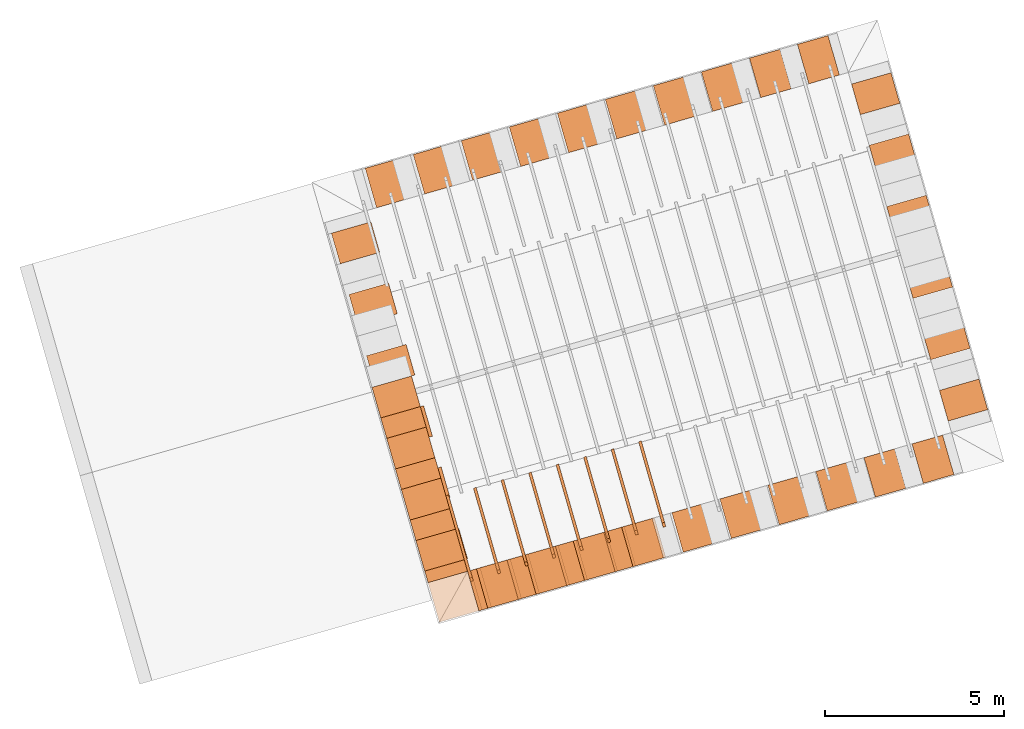
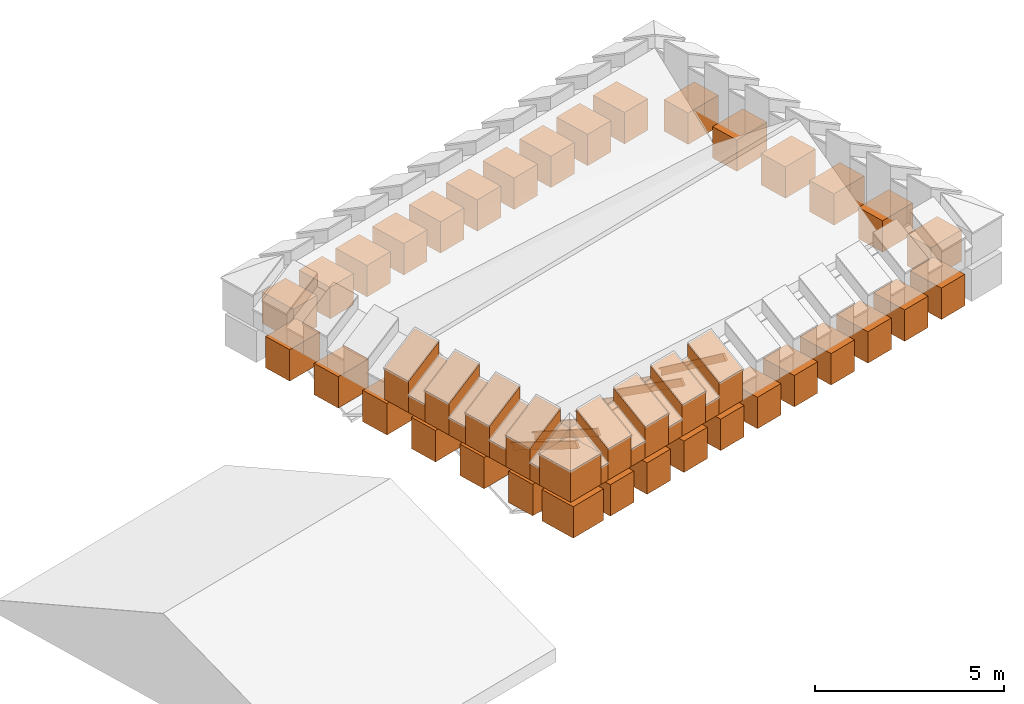
# One storey, part 5 of 10: 58 proxies.
"""IFC4 building model written with IfcOpenShell, lengths in metres."""

from ifc_helpers import new_model, entity, si_unit, converted_unit, derived_unit, direction, frame, origin_with_axes, place, context, subcontext, project, spatial, polygons, source, transform, mapped, material, type_object, element, save


model = new_model("IFC4")

# Units and contexts
model_context = context("Model", 3, precision=1e-05, world=origin_with_axes(), true_north=direction((0.0, 1.0)))
body_context = subcontext(model_context, "Body", "Model", "MODEL_VIEW")
ifc_project = project(units=[si_unit("LENGTHUNIT", "METRE"), si_unit("AREAUNIT", "SQUARE_METRE"), si_unit("VOLUMEUNIT", "CUBIC_METRE"), converted_unit("PLANEANGLEUNIT", "DEGREE", entity("IfcPlaneAngleMeasure", 0.0174532925199433), si_unit("PLANEANGLEUNIT", "RADIAN"), dimensions=[0, 0, 0, 0, 0, 0, 0]), converted_unit("TIMEUNIT", "Year", entity("IfcTimeMeasure", 31557600.0), si_unit("TIMEUNIT", "SECOND"), dimensions=[0, 0, 1, 0, 0, 0, 0]), si_unit("MASSUNIT", "GRAM", prefix="KILO"), si_unit("THERMODYNAMICTEMPERATUREUNIT", "DEGREE_CELSIUS"), si_unit("LUMINOUSINTENSITYUNIT", "LUMEN"), si_unit("ENERGYUNIT", "JOULE", prefix="MEGA"), derived_unit("THERMALCONDUCTANCEUNIT", [(si_unit("POWERUNIT", "WATT"), 1), (si_unit("LENGTHUNIT", "METRE"), -1), (si_unit("THERMODYNAMICTEMPERATUREUNIT", "KELVIN"), -1)]), derived_unit("SPECIFICHEATCAPACITYUNIT", [(si_unit("ENERGYUNIT", "JOULE"), 1), (si_unit("MASSUNIT", "GRAM", prefix="KILO"), -1), (si_unit("THERMODYNAMICTEMPERATUREUNIT", "KELVIN"), -1)]), derived_unit("MASSDENSITYUNIT", [(si_unit("MASSUNIT", "GRAM", prefix="KILO"), 1), (si_unit("VOLUMEUNIT", "CUBIC_METRE"), -1)])], contexts=[model_context])

# Site, building, storey
site_placement = place(None, frame((0.0, 0.0, 0.0), z_axis=(0.0, 0.0, 1.0), x_axis=(0.9612616959383189, 0.2756373558169991, 0.0)))
site = spatial("IfcSite", under=ifc_project, at=site_placement, CompositionType="ELEMENT")
building_placement = place(site_placement, origin_with_axes())
building = spatial("IfcBuilding", under=site, at=building_placement, CompositionType="ELEMENT")
storey_placement = place(building_placement, frame((0.0, 0.0, 11.0), z_axis=(0.0, 0.0, 1.0), x_axis=(1.0, 0.0, 0.0)))
storey = spatial("IfcBuildingStorey", under=building, at=storey_placement, Name="Dach", CompositionType="ELEMENT", Elevation=11.0)

# Proxies
ifc_material_1 = material()
building_element_proxy_type_1 = type_object("IfcBuildingElementProxyType", PredefinedType="NOTDEFINED")
shared_shape = source(origin_with_axes(), body_context, "Body", "Tessellation", [
    polygons([(29.30246798608733, 19.30664615992103, 30.0), (29.30246799091987, 18.15664615992103, 30.0), (29.30246799091987, 18.15664615992103, 31.0117), (29.30246798608733, 19.30664615992103, 31.0117), (30.19247054778258, 19.30664616366101, 30.0), (30.19247055261512, 18.15664616366101, 30.0), (30.19247055261512, 18.15664616366101, 31.0117), (30.19247054778258, 19.30664616366101, 31.0117)], [[[1, 2, 3, 4]], [[2, 1, 5, 6]], [[2, 6, 7, 3]], [[4, 3, 7, 8]], [[1, 4, 8, 5]], [[7, 6, 5, 8]]], closed=True),
])
for number, where, z_axis, x_axis in (
    (1, (-2.796313213619531, 1.1039726491191e-05, -31.0), (0.0, 0.0, 1.0), (1.0, 0.0, 0.0)),
    (2, (12.29478534732825, 43.55533738798009, -30.99999999999999), (0.0, 0.0, 1.0), (-4.202178160994663e-09, -1.0, 0.0)),
    (3, (-2.846450438079298, 41.77164896513582, -31.00000000000001), (0.0, 0.0, 1.0), (-4.202178160994663e-09, -1.0, 0.0)),
    (4, (-2.84645043807933, 38.2042721194473, -31.00000000000002), (0.0, 0.0, 1.0), (-4.202178160994663e-09, -1.0, 0.0)),
    (5, (-2.84645043807928, 43.55533738798009, -31.00000000000001), (0.0, 0.0, 1.0), (-4.202178160994663e-09, -1.0, 0.0)),
    (6, (12.29478534732826, 45.33902581082435, -30.99999999999999), (0.0, 0.0, 1.0), (-4.202178160994663e-09, -1.0, 0.0)),
    (7, (-1.398176188643454, 5.520714232432056e-06, -31.0), (0.0, 0.0, 1.0), (1.0, 0.0, 0.0)),
    (8, (12.2947853473282, 38.2042721194473, -31.00000000000001), (0.0, 0.0, 1.0), (-4.202178160994663e-09, -1.0, 0.0)),
    (9, (-2.846450438079266, 45.33902581082435, -31.00000000000001), (0.0, 0.0, 1.0), (-4.202178160994663e-09, -1.0, 0.0)),
    (10, (-2.846450438079248, 47.12271423366862, -31.0), (0.0, 0.0, 1.0), (-4.202178160994663e-09, -1.0, 0.0)),
    (11, (-3.916366737399812e-05, 1.701973673107204e-09, -31.0), (0.0, 0.0, 1.0), (1.0, 0.0, 0.0)),
    (12, (-2.846450438079312, 39.98796054229156, -31.00000000000002), (0.0, 0.0, 1.0), (-4.202178160994663e-09, -1.0, 0.0)),
    (13, (-4.194450238595611, 1.655873874994995e-05, -31.0), (0.0, 0.0, 1.0), (1.0, 0.0, 0.0)),
    (14, (12.29478534732822, 39.98796054229156, -31.0), (0.0, 0.0, 1.0), (-4.202178160994663e-09, -1.0, 0.0)),
    (15, (12.29478534732823, 41.77164896513582, -31.0), (0.0, 0.0, 1.0), (-4.202178160994663e-09, -1.0, 0.0)),
    (16, (-11.185135363476, 4.41538000437447e-05, -31.0), (0.0, 0.0, 1.0), (1.0, 0.0, 0.0)),
    (17, (-3.916366737399812e-05, -11.63124470756036, -31.0), (0.0, 0.0, 1.0), (1.0, 0.0, 0.0)),
    (18, (-1.398176188643454, -11.6312391885481, -31.0), (0.0, 0.0, 1.0), (1.0, 0.0, 0.0)),
    (19, (-6.990724288547767, 2.759676326746785e-05, -31.0), (0.0, 0.0, 1.0), (1.0, 0.0, 0.0)),
    (20, (-12.58327238845208, 4.967281230250364e-05, -31.0), (0.0, 0.0, 1.0), (1.0, 0.0, 0.0)),
    (21, (-2.796313213619531, -11.63123366953584, -31.0), (0.0, 0.0, 1.0), (1.0, 0.0, 0.0)),
    (22, (12.29478534732828, 47.12271423366862, -30.99999999999998), (0.0, 0.0, 1.0), (-4.202178160994663e-09, -1.0, 0.0)),
    (23, (-8.388861313523847, 3.31157755262268e-05, -31.0), (0.0, 0.0, 1.0), (1.0, 0.0, 0.0)),
    (24, (-11.185135363476, -11.63120055546229, -31.0), (0.0, 0.0, 1.0), (1.0, 0.0, 0.0)),
    (25, (-9.786998338499924, 3.863478778498575e-05, -31.0), (0.0, 0.0, 1.0), (1.0, 0.0, 0.0)),
    (26, (-4.194450238595611, -11.63122815052358, -31.0), (0.0, 0.0, 1.0), (1.0, 0.0, 0.0)),
    (27, (-8.388861313523847, -11.63121159348681, -31.0), (0.0, 0.0, 1.0), (1.0, 0.0, 0.0)),
    (28, (-5.592587263571691, -11.63122263151133, -31.0), (0.0, 0.0, 1.0), (1.0, 0.0, 0.0)),
    (29, (-6.990724288547767, -11.63121711249907, -31.0), (0.0, 0.0, 1.0), (1.0, 0.0, 0.0)),
    (30, (-5.592587263571691, 2.20777510087089e-05, -31.0), (0.0, 0.0, 1.0), (1.0, 0.0, 0.0)),
    (31, (-12.58327238845208, -11.63119503645003, -31.0), (0.0, 0.0, 1.0), (1.0, 0.0, 0.0)),
    (32, (-9.786998338499924, -11.63120607447455, -31.0), (0.0, 0.0, 1.0), (1.0, 0.0, 0.0)),
):
    element("IfcBuildingElementProxy", number, at=place(storey_placement, frame(where, z_axis=z_axis, x_axis=x_axis)), inside=storey, type_object=building_element_proxy_type_1, material=ifc_material_1, PredefinedType="NOTDEFINED", context=body_context, shape_type="MappedRepresentation", body=[
        mapped(shared_shape, transform((0.0, 0.0, 0.0))),
    ])
ifc_material_2 = material()
building_element_proxy_type_2 = type_object("IfcBuildingElementProxyType", PredefinedType="NOTDEFINED")
proxy_1_placement = place(storey_placement, frame((-32.66955969550476, -0.05131726657445945, -11.3285), z_axis=(0.0, 0.0, 1.0), x_axis=(1.0, 0.0, 0.0)))
element("IfcBuildingElementProxy", 33, at=proxy_1_placement, inside=storey, type_object=building_element_proxy_type_2, material=ifc_material_2, Name="008", PredefinedType="NOTDEFINED", context=body_context, shape_type="Tessellation", body=[
    polygons([(54.63241932296884, 7.402293728881853, 12.27656567887195), (54.63241932296884, 7.526718754969063, 12.458), (54.63241932296884, 9.890190777523967, 10.83716516437243), (54.63241932296884, 9.787341089745903, 10.83716516437243), (54.63241932296884, 9.787341089745905, 10.64093478913915), (54.71241932296884, 7.402293728881853, 12.27656567887195), (54.71241932296884, 7.526718754969063, 12.458), (54.71241932296884, 9.89876167590857, 10.83128736656403), (54.71241932296884, 9.787341089745903, 10.83128736656403), (54.71241932296884, 9.787341089745905, 10.64093478913915)], [[[1, 2, 3, 4, 5]], [[2, 1, 6, 7]], [[3, 2, 7, 8]], [[4, 3, 8, 9]], [[5, 4, 9, 10]], [[1, 5, 10, 6]], [[6, 10, 9, 8, 7]]], closed=True),
])
proxy_2_placement = place(storey_placement, frame((-32.66955969550476, -0.05131726657445945, -11.3285), z_axis=(0.0, 0.0, 1.0), x_axis=(1.0, 0.0, 0.0)))
element("IfcBuildingElementProxy", 34, at=proxy_2_placement, inside=storey, type_object=building_element_proxy_type_2, material=ifc_material_2, Name="008", PredefinedType="NOTDEFINED", context=body_context, shape_type="Tessellation", body=[
    polygons([(53.83241932296884, 7.405427048607078, 12.27445621239661), (53.83241932296884, 7.526718754969064, 12.458), (53.83241932296884, 9.890489870775953, 10.89594314245643), (53.83241932296884, 9.787341089745903, 10.89594314245643), (53.83241932296884, 9.787341089745905, 10.70040991952188), (53.91241932296884, 7.405427048607078, 12.27445621239661), (53.91241932296884, 7.526718754969064, 12.458), (53.91241932296884, 9.899384405323113, 10.89006534464803), (53.91241932296884, 9.787341089745903, 10.89006534464803), (53.91241932296884, 9.787341089745905, 10.70040991952187)], [[[1, 2, 3, 4, 5]], [[2, 1, 6, 7]], [[3, 2, 7, 8]], [[4, 3, 8, 9]], [[5, 4, 9, 10]], [[1, 5, 10, 6]], [[6, 10, 9, 8, 7]]], closed=True),
])
proxy_3_placement = place(storey_placement, frame((-32.66955969550476, -0.05131726657445945, -11.3285), z_axis=(0.0, 0.0, 1.0), x_axis=(1.0, 0.0, 0.0)))
element("IfcBuildingElementProxy", 35, at=proxy_3_placement, inside=storey, type_object=building_element_proxy_type_2, material=ifc_material_2, Name="008", PredefinedType="NOTDEFINED", context=body_context, shape_type="Tessellation", body=[
    polygons([(53.03241932296884, 7.408901351535608, 12.27220694456413), (53.03241932296884, 7.526718754969068, 12.458), (53.03241932296884, 9.89732588131564, 10.95472112054043), (53.03241932296884, 9.787341089745903, 10.95472112054043), (53.03241932296884, 9.787341089745905, 10.76396115183796), (53.11241932296884, 7.408901351535608, 12.27220694456413), (53.11241932296884, 7.526718754969068, 12.458), (53.11241932296884, 9.90659491952419, 10.94884332273203), (53.11241932296884, 9.787341089745903, 10.94884332273203), (53.11241932296884, 9.787341089745905, 10.76396115183796)], [[[1, 2, 3, 4, 5]], [[2, 1, 6, 7]], [[3, 2, 7, 8]], [[4, 3, 8, 9]], [[5, 4, 9, 10]], [[1, 5, 10, 6]], [[6, 10, 9, 8, 7]]], closed=True),
])
proxy_4_placement = place(storey_placement, frame((-32.66955969550476, -0.05131726657445945, -11.3285), z_axis=(0.0, 0.0, 1.0), x_axis=(1.0, 0.0, 0.0)))
element("IfcBuildingElementProxy", 36, at=proxy_4_placement, inside=storey, type_object=building_element_proxy_type_2, material=ifc_material_2, Name="008", PredefinedType="NOTDEFINED", context=body_context, shape_type="Tessellation", body=[
    polygons([(52.23241932296884, 7.412448525633401, 12.27000448226733), (52.23241932296884, 7.526718754969066, 12.458), (52.23241932296884, 9.90318808034087, 11.01349909862444), (52.23241932296884, 9.787341089745903, 11.01349909862444), (52.23241932296884, 9.787341089745903, 10.82646199135219), (52.31241932296884, 7.412448525633401, 12.27000448226733), (52.31241932296884, 7.526718754969066, 12.458), (52.31241932296884, 9.912858137437476, 11.00762130081604), (52.31241932296884, 9.787341089745903, 11.00762130081604), (52.31241932296884, 9.787341089745903, 10.82646199135219)], [[[1, 2, 3, 4, 5]], [[2, 1, 6, 7]], [[3, 2, 7, 8]], [[4, 3, 8, 9]], [[5, 4, 9, 10]], [[1, 5, 10, 6]], [[7, 6, 10, 9, 8]]], closed=True),
])
proxy_5_placement = place(storey_placement, frame((-32.66955969550476, -0.05131726657445945, -11.3285), z_axis=(0.0, 0.0, 1.0), x_axis=(1.0, 0.0, 0.0)))
element("IfcBuildingElementProxy", 37, at=proxy_5_placement, inside=storey, type_object=building_element_proxy_type_2, material=ifc_material_2, Name="008", PredefinedType="NOTDEFINED", context=body_context, shape_type="Tessellation", body=[
    polygons([(50.63241932296884, 7.419849216181192, 12.26570100967694), (50.63241932296884, 7.526718754969065, 12.458), (50.63241932296884, 9.914397939064663, 11.13105505479244), (50.63241932296884, 9.787341089745901, 11.13105505479244), (50.63241932296884, 9.787341089745903, 10.94997509667636), (50.71241932296884, 7.419849216181192, 12.26570100967694), (50.71241932296884, 7.526718754969065, 12.458), (50.71241932296884, 9.924974335264164, 11.12517725698404), (50.71241932296883, 9.787341089745901, 11.12517725698404), (50.71241932296883, 9.787341089745903, 10.94997509667636)], [[[1, 2, 3, 4, 5]], [[2, 1, 6, 7]], [[3, 2, 7, 8]], [[4, 3, 8, 9]], [[5, 4, 9, 10]], [[1, 5, 10, 6]], [[7, 6, 10, 9, 8]]], closed=True),
])
proxy_6_placement = place(storey_placement, frame((-32.66955969550476, -0.05131726657445945, -11.3285), z_axis=(0.0, 0.0, 1.0), x_axis=(1.0, 0.0, 0.0)))
element("IfcBuildingElementProxy", 38, at=proxy_6_placement, inside=storey, type_object=building_element_proxy_type_2, material=ifc_material_2, Name="008", PredefinedType="NOTDEFINED", context=body_context, shape_type="Tessellation", body=[
    polygons([(51.43241932296884, 7.415724363527985, 12.2680519937756), (51.43241932296884, 7.526718754969065, 12.458), (51.43241932296884, 9.898147644674735, 11.07227707670844), (51.43241932296884, 9.787341089745903, 11.07227707670844), (51.43241932296884, 9.787341089745903, 10.88221930992492), (51.51241932296884, 7.415724363527985, 12.2680519937756), (51.51241932296884, 7.526718754969065, 12.458), (51.51241932296884, 9.908206495038254, 11.06639927890004), (51.51241932296884, 9.787341089745903, 11.06639927890004), (51.51241932296884, 9.787341089745903, 10.88221930992492)], [[[1, 2, 3, 4, 5]], [[2, 1, 6, 7]], [[3, 2, 7, 8]], [[4, 3, 8, 9]], [[5, 4, 9, 10]], [[1, 5, 10, 6]], [[6, 10, 9, 8, 7]]], closed=True),
])
proxy_7_placement = place(storey_placement, frame((-32.66955969550475, -0.05131726657445945, -11.3285), z_axis=(0.0, 0.0, 1.0), x_axis=(1.0, 0.0, 0.0)))
element("IfcBuildingElementProxy", 39, at=proxy_7_placement, inside=storey, type_object=building_element_proxy_type_2, material=ifc_material_2, Name="008", PredefinedType="NOTDEFINED", context=body_context, shape_type="Tessellation", body=[
    polygons([(49.83241932296884, 7.423389784873412, 12.2637755835664), (49.83241932296884, 7.526718754969066, 12.458), (49.83241932296884, 9.910454786615606, 11.18983303287644), (49.83241932296883, 9.787341089745901, 11.18983303287644), (49.83241932296883, 9.787341089745903, 11.00613425209013), (49.91241932296884, 7.423389784873412, 12.2637755835664), (49.91241932296884, 7.526718754969066, 12.458), (49.91241932296884, 9.921503109735388, 11.18395523506804), (49.91241932296883, 9.787341089745901, 11.18395523506804), (49.91241932296883, 9.787341089745903, 11.00613425209013)], [[[1, 2, 3, 4, 5]], [[2, 1, 6, 7]], [[3, 2, 7, 8]], [[4, 3, 8, 9]], [[5, 4, 9, 10]], [[1, 5, 10, 6]], [[7, 6, 10, 9, 8]]], closed=True),
])
proxy_8_placement = place(storey_placement, frame((-32.66955969550475, -0.05131726657445945, -11.3285), z_axis=(0.0, 0.0, 1.0), x_axis=(1.0, 0.0, 0.0)))
element("IfcBuildingElementProxy", 40, at=proxy_8_placement, inside=storey, type_object=building_element_proxy_type_2, material=ifc_material_2, Name="008", PredefinedType="NOTDEFINED", context=body_context, shape_type="Tessellation", body=[
    polygons([(49.03241932296884, 7.427506488142882, 12.26164082371529), (49.03241932296884, 7.526718754969065, 12.458), (49.03241932296884, 9.920320204592786, 11.24861101096044), (49.03241932296884, 9.787341089745901, 11.24861101096044), (49.03241932296884, 9.787341089745903, 11.06931284297234), (49.11241932296884, 7.427506488142882, 12.26164082371529), (49.11241932296884, 7.526718754969065, 12.458), (49.11241932296884, 9.931953438798063, 11.24273321315204), (49.11241932296884, 9.787341089745901, 11.24273321315204), (49.11241932296884, 9.787341089745903, 11.06931284297234)], [[[1, 2, 3, 4, 5]], [[2, 1, 6, 7]], [[3, 2, 7, 8]], [[4, 3, 8, 9]], [[5, 4, 9, 10]], [[1, 5, 10, 6]], [[6, 10, 9, 8, 7]]], closed=True),
])
building_element_proxy_type_3 = type_object("IfcBuildingElementProxyType", Name="336 x 1150", PredefinedType="NOTDEFINED")
proxy_9_placement = place(storey_placement, frame((15.7878596203137, 7.843604214549005, 0.2019994043252051), z_axis=(0.0, 0.0, 1.0), x_axis=(1.851628352347186e-10, -1.0, 0.0)))
element("IfcBuildingElementProxy", 41, at=proxy_9_placement, inside=storey, type_object=building_element_proxy_type_3, material=ifc_material_1, PredefinedType="NOTDEFINED", context=body_context, shape_type="Tessellation", body=[
    polygons([(0.168202757876692, 0.5750000000000011, 1.258340042868717), (0.168202757876692, 0.5750000000000011, 0.0), (-0.1682027578766929, 0.5750000000000011, 0.0), (-0.1682027578766929, 0.5750000000000011, 1.258340042868717), (0.168202757876692, -0.5749999999999993, 0.5616599571312832), (0.168202757876692, -0.5749999999999993, 0.0), (-0.1682027578766929, -0.5749999999999993, 0.0), (-0.1682027578766929, -0.5749999999999993, 0.5616599571312832)], [[[1, 2, 3, 4]], [[5, 6, 2, 1]], [[3, 2, 6, 7]], [[4, 3, 7, 8]], [[5, 1, 4, 8]], [[8, 7, 6, 5]]], closed=True),
])
building_element_proxy_type_4 = type_object("IfcBuildingElementProxyType", Name="259 x 1150", PredefinedType="NOTDEFINED")
proxy_10_placement = place(storey_placement, frame((16.49234043598541, 7.10040145610065, 0.2019994110307355), z_axis=(0.0, 0.0, 1.0), x_axis=(1.0, 0.0, 0.0)))
element("IfcBuildingElementProxy", 42, at=proxy_10_placement, inside=storey, type_object=building_element_proxy_type_4, material=ifc_material_1, PredefinedType="NOTDEFINED", context=body_context, shape_type="Tessellation", body=[
    polygons([(-0.1294808085213468, -0.5749999999999993, 0.5616599571312832), (-0.1294808085213468, -0.5749999999999993, 0.0), (0.1294808085213504, -0.5749999999999993, 0.0), (0.1294808085213504, -0.5749999999999993, 0.5616599571312832), (-0.1294808085213468, 0.5750000000000002, 1.258340042868717), (-0.1294808085213468, 0.5750000000000002, 0.0), (0.1294808085213504, 0.5750000000000002, 0.0), (0.1294808085213504, 0.5750000000000002, 1.258340042868717)], [[[1, 2, 3, 4]], [[5, 6, 2, 1]], [[3, 2, 6, 7]], [[4, 3, 7, 8]], [[5, 1, 4, 8]], [[8, 7, 6, 5]]], closed=True),
])
building_element_proxy_type_5 = type_object("IfcBuildingElementProxyType", Name="1150 x 1150", PredefinedType="NOTDEFINED")
proxy_11_placement = place(storey_placement, frame((15.78785962699885, 7.100401456100668, 0.2019994110307373), z_axis=(0.0, 0.0, 1.0), x_axis=(0.0, 1.0, 0.0)))
element("IfcBuildingElementProxy", 43, at=proxy_11_placement, inside=storey, type_object=building_element_proxy_type_5, material=ifc_material_1, PredefinedType="NOTDEFINED", context=body_context, shape_type="Tessellation", body=[
    polygons([(-0.5750000000000002, -0.5749999999999993, 1.011699999999999), (-0.5750000000000002, -0.5749999999999993, 0.0), (0.5750000000000002, -0.5749999999999993, 0.0), (0.5750000000000002, -0.5749999999999993, 1.011699999999999), (-0.5750000000000002, 0.5750000000000011, 1.011699999999999), (-0.5750000000000002, 0.5750000000000011, 0.0), (0.5750000000000002, 0.5750000000000011, 0.0), (0.5750000000000002, 0.5750000000000011, 1.011699999999999)], [[[1, 2, 3, 4]], [[5, 6, 2, 1]], [[3, 2, 6, 7]], [[4, 3, 7, 8]], [[5, 1, 4, 8]], [[8, 7, 6, 5]]], closed=True),
])
building_element_proxy_type_6 = type_object("IfcBuildingElementProxyType", Name="519 x 1150", PredefinedType="NOTDEFINED")
proxy_12_placement = place(storey_placement, frame((17.77129984003987, 7.100401459578842, 0.2019994076779703), z_axis=(0.0, 0.0, 1.0), x_axis=(1.0, 0.0, 0.0)))
element("IfcBuildingElementProxy", 44, at=proxy_12_placement, inside=storey, type_object=building_element_proxy_type_6, material=ifc_material_1, PredefinedType="NOTDEFINED", context=body_context, shape_type="Tessellation", body=[
    polygons([(-0.2594814554022626, -0.5750000000000002, 0.5616599571312832), (-0.2594814554022626, -0.5750000000000002, 0.0), (0.2594814554022662, -0.5750000000000002, 0.0), (0.2594814554022662, -0.5750000000000002, 0.5616599571312832), (-0.2594814554022626, 0.5750000000000002, 1.258340042868717), (-0.2594814554022626, 0.5750000000000002, 0.0), (0.2594814554022662, 0.5750000000000002, 0.0), (0.2594814554022662, 0.5750000000000002, 1.258340042868717)], [[[1, 2, 3, 4]], [[5, 6, 2, 1]], [[3, 2, 6, 7]], [[4, 3, 7, 8]], [[5, 1, 4, 8]], [[8, 7, 6, 5]]], closed=True),
])
proxy_13_placement = place(storey_placement, frame((20.58922398683654, 7.100401466535223, 0.2019994076779703), z_axis=(0.0, 0.0, 1.0), x_axis=(1.0, 0.0, 0.0)))
element("IfcBuildingElementProxy", 45, at=proxy_13_placement, inside=storey, type_object=building_element_proxy_type_6, material=ifc_material_1, PredefinedType="NOTDEFINED", context=body_context, shape_type="Tessellation", body=[
    polygons([(-0.2594796273897373, -0.5750000000000002, 0.5616599571312832), (-0.2594796273897373, -0.5750000000000002, 0.0), (0.2594796273897408, -0.5750000000000002, 0.0), (0.2594796273897408, -0.5750000000000002, 0.5616599571312832), (-0.2594796273897373, 0.5750000000000002, 1.258340042868717), (-0.2594796273897373, 0.5750000000000002, 0.0), (0.2594796273897408, 0.5750000000000002, 0.0), (0.2594796273897408, 0.5750000000000002, 1.258340042868717)], [[[1, 2, 3, 4]], [[5, 6, 2, 1]], [[3, 2, 6, 7]], [[4, 3, 7, 8]], [[5, 1, 4, 8]], [[8, 7, 6, 5]]], closed=True),
])
proxy_14_placement = place(storey_placement, frame((19.18025923901053, 7.100401463057034, 0.2019994076779703), z_axis=(0.0, 0.0, 1.0), x_axis=(1.0, 0.0, 0.0)))
element("IfcBuildingElementProxy", 46, at=proxy_14_placement, inside=storey, type_object=building_element_proxy_type_6, material=ifc_material_1, PredefinedType="NOTDEFINED", context=body_context, shape_type="Tessellation", body=[
    polygons([(-0.2594846541917235, -0.5750000000000002, 0.5616599571312832), (-0.2594846541917235, -0.5750000000000002, 0.0), (0.2594846541917271, -0.5750000000000002, 0.0), (0.2594846541917271, -0.5750000000000002, 0.5616599571312832), (-0.2594846541917235, 0.5750000000000002, 1.258340042868717), (-0.2594846541917235, 0.5750000000000002, 0.0), (0.2594846541917271, 0.5750000000000002, 0.0), (0.2594846541917271, 0.5750000000000002, 1.258340042868717)], [[[1, 2, 3, 4]], [[5, 6, 2, 1]], [[3, 2, 6, 7]], [[4, 3, 7, 8]], [[5, 1, 4, 8]], [[8, 7, 6, 5]]], closed=True),
])
building_element_proxy_type_7 = type_object("IfcBuildingElementProxyType", Name="596 x 1150", PredefinedType="NOTDEFINED")
proxy_15_placement = place(storey_placement, frame((15.78785962700646, 12.17282092050785, 0.2019994076779685), z_axis=(0.0, 0.0, 1.0), x_axis=(1.851628352347186e-10, -1.0, 0.0)))
element("IfcBuildingElementProxy", 47, at=proxy_15_placement, inside=storey, type_object=building_element_proxy_type_7, material=ifc_material_1, PredefinedType="NOTDEFINED", context=body_context, shape_type="Tessellation", body=[
    polygons([(0.2981999999999996, 0.5750000000000011, 1.258340042868717), (0.2981999999999996, 0.5750000000000011, 0.0), (-0.2982000000000014, 0.5749999999999975, 0.0), (-0.2982000000000014, 0.5749999999999975, 1.258340042868717), (0.2981999999999996, -0.5749999999999993, 0.5616599571312832), (0.2981999999999996, -0.5749999999999993, 0.0), (-0.2982000000000014, -0.5749999999999993, 0.0), (-0.2982000000000014, -0.5749999999999993, 0.5616599571312832)], [[[1, 2, 3, 4]], [[5, 6, 2, 1]], [[3, 2, 6, 7]], [[4, 3, 7, 8]], [[5, 1, 4, 8]], [[8, 7, 6, 5]]], closed=True),
])
proxy_16_placement = place(storey_placement, frame((15.78785962710008, 10.68641511496412, 0.2019994076779685), z_axis=(0.0, 0.0, 1.0), x_axis=(1.851628352347186e-10, -1.0, 0.0)))
element("IfcBuildingElementProxy", 48, at=proxy_16_placement, inside=storey, type_object=building_element_proxy_type_7, material=ifc_material_1, PredefinedType="NOTDEFINED", context=body_context, shape_type="Tessellation", body=[
    polygons([(0.2981999999999996, 0.5749999999999993, 1.258340042868717), (0.2981999999999996, 0.5749999999999993, 0.0), (-0.2982000000000014, 0.5749999999999993, 0.0), (-0.2982000000000014, 0.5749999999999993, 1.258340042868717), (0.2981999999999996, -0.5749999999999993, 0.5616599571312832), (0.2981999999999996, -0.5749999999999993, 0.0), (-0.2982000000000014, -0.5749999999999993, 0.0), (-0.2982000000000014, -0.5749999999999993, 0.5616599571312832)], [[[1, 2, 3, 4]], [[5, 6, 2, 1]], [[3, 2, 6, 7]], [[4, 3, 7, 8]], [[5, 1, 4, 8]], [[8, 7, 6, 5]]], closed=True),
])
proxy_17_placement = place(storey_placement, frame((15.78785962719371, 9.20000930942039, 0.2019994076779685), z_axis=(0.0, 0.0, 1.0), x_axis=(1.851628352347186e-10, -1.0, 0.0)))
element("IfcBuildingElementProxy", 49, at=proxy_17_placement, inside=storey, type_object=building_element_proxy_type_7, material=ifc_material_1, PredefinedType="NOTDEFINED", context=body_context, shape_type="Tessellation", body=[
    polygons([(0.2981999999999996, 0.5750000000000011, 1.258340042868717), (0.2981999999999996, 0.5750000000000011, 0.0), (-0.2982000000000014, 0.5749999999999975, 0.0), (-0.2982000000000014, 0.5749999999999975, 1.258340042868717), (0.2981999999999996, -0.5749999999999993, 0.5616599571312832), (0.2981999999999996, -0.5749999999999993, 0.0), (-0.2982000000000014, -0.5749999999999993, 0.0), (-0.2982000000000014, -0.5749999999999993, 0.5616599571312832)], [[[1, 2, 3, 4]], [[5, 6, 2, 1]], [[3, 2, 6, 7]], [[4, 3, 7, 8]], [[5, 1, 4, 8]], [[8, 7, 6, 5]]], closed=True),
])
building_element_proxy_type_8 = type_object("IfcBuildingElementProxyType", Name="890 x 1150", PredefinedType="NOTDEFINED")
proxy_18_placement = place(storey_placement, frame((15.78785962695965, 12.9160238232797, 0.2019994076779703), z_axis=(0.0, 0.0, 1.0), x_axis=(1.851370780605473e-10, -1.0, 0.0)))
element("IfcBuildingElementProxy", 50, at=proxy_18_placement, inside=storey, type_object=building_element_proxy_type_8, material=ifc_material_1, PredefinedType="NOTDEFINED", context=body_context, shape_type="Tessellation", body=[
    polygons([(0.4450012808476238, 0.5749999999999993, 1.708340042868718), (0.4450012808476238, 0.5749999999999993, 0.0), (-0.4450012808476256, 0.5749999999999993, 0.0), (-0.4450012808476256, 0.5749999999999993, 1.708340042868718), (0.4450012808476238, -0.5750000000000011, 1.011659957131284), (0.4450012808476238, -0.5750000000000011, 0.0), (-0.4450012808476256, -0.5750000000000011, 0.0), (-0.4450012808476256, -0.5750000000000011, 1.011659957131284)], [[[1, 2, 3, 4]], [[5, 6, 2, 1]], [[3, 2, 6, 7]], [[4, 3, 7, 8]], [[5, 1, 4, 8]], [[8, 7, 6, 5]]], closed=True),
])
proxy_19_placement = place(storey_placement, frame((15.78785962708354, 11.42961855837738, 0.2019994076779703), z_axis=(0.0, 0.0, 1.0), x_axis=(1.851370780605473e-10, -1.0, 0.0)))
element("IfcBuildingElementProxy", 51, at=proxy_19_placement, inside=storey, type_object=building_element_proxy_type_8, material=ifc_material_1, PredefinedType="NOTDEFINED", context=body_context, shape_type="Tessellation", body=[
    polygons([(0.4450012808476238, 0.5749999999999993, 1.708340042868718), (0.4450012808476238, 0.5749999999999993, 0.0), (-0.4450012808476256, 0.5750000000000028, 0.0), (-0.4450012808476256, 0.5750000000000028, 1.708340042868718), (0.4450012808476238, -0.5749999999999993, 1.011659957131284), (0.4450012808476238, -0.5749999999999993, 0.0), (-0.4450012808476256, -0.5750000000000011, 0.0), (-0.4450012808476256, -0.5750000000000011, 1.011659957131284)], [[[1, 2, 3, 4]], [[5, 6, 2, 1]], [[3, 2, 6, 7]], [[4, 3, 7, 8]], [[5, 1, 4, 8]], [[8, 7, 6, 5]]], closed=True),
])
proxy_20_placement = place(storey_placement, frame((15.78785962720742, 9.943213293475067, 0.2019994076779703), z_axis=(0.0, 0.0, 1.0), x_axis=(1.851370780605473e-10, -1.0, 0.0)))
element("IfcBuildingElementProxy", 52, at=proxy_20_placement, inside=storey, type_object=building_element_proxy_type_8, material=ifc_material_1, PredefinedType="NOTDEFINED", context=body_context, shape_type="Tessellation", body=[
    polygons([(0.4450012808476238, 0.5750000000000011, 1.708340042868718), (0.4450012808476238, 0.5750000000000011, 0.0), (-0.4450012808476256, 0.5750000000000011, 0.0), (-0.4450012808476256, 0.5750000000000011, 1.708340042868718), (0.4450012808476238, -0.5750000000000011, 1.011659957131284), (0.4450012808476238, -0.5750000000000011, 0.0), (-0.4450012808476256, -0.5750000000000011, 0.0), (-0.4450012808476256, -0.5750000000000011, 1.011659957131284)], [[[1, 2, 3, 4]], [[5, 6, 2, 1]], [[3, 2, 6, 7]], [[4, 3, 7, 8]], [[5, 1, 4, 8]], [[8, 7, 6, 5]]], closed=True),
])
proxy_21_placement = place(storey_placement, frame((15.78785962733131, 8.45680802857275, 0.2019994076779703), z_axis=(0.0, 0.0, 1.0), x_axis=(1.851370780605473e-10, -1.0, 0.0)))
element("IfcBuildingElementProxy", 53, at=proxy_21_placement, inside=storey, type_object=building_element_proxy_type_8, material=ifc_material_1, PredefinedType="NOTDEFINED", context=body_context, shape_type="Tessellation", body=[
    polygons([(0.4450012808476238, 0.5750000000000011, 1.708340042868718), (0.4450012808476238, 0.5750000000000011, 0.0), (-0.4450012808476256, 0.5750000000000011, 0.0), (-0.4450012808476256, 0.5750000000000011, 1.708340042868718), (0.4450012808476238, -0.5749999999999993, 1.011659957131284), (0.4450012808476238, -0.5749999999999993, 0.0), (-0.4450012808476256, -0.5750000000000011, 0.0), (-0.4450012808476256, -0.5750000000000011, 1.011659957131284)], [[[1, 2, 3, 4]], [[5, 6, 2, 1]], [[3, 2, 6, 7]], [[4, 3, 7, 8]], [[5, 1, 4, 8]], [[8, 7, 6, 5]]], closed=True),
])
proxy_22_placement = place(storey_placement, frame((21.29370424893923, 7.100401468622136, 0.2019994076779703), z_axis=(0.0, 0.0, 1.0), x_axis=(1.0, 0.0, 0.0)))
element("IfcBuildingElementProxy", 54, at=proxy_22_placement, inside=storey, type_object=building_element_proxy_type_8, material=ifc_material_1, PredefinedType="NOTDEFINED", context=body_context, shape_type="Tessellation", body=[
    polygons([(-0.4450012808476238, -0.5749999999999993, 1.011659957131284), (-0.4450012808476238, -0.5749999999999993, 0.0), (0.4450012808476238, -0.5750000000000002, 0.0), (0.4450012808476238, -0.5750000000000002, 1.011659957131284), (-0.4450012808476238, 0.5750000000000002, 1.708340042868718), (-0.4450012808476238, 0.5750000000000002, 0.0), (0.4450012808476238, 0.5749999999999993, 0.0), (0.4450012808476238, 0.5749999999999993, 1.708340042868718)], [[[1, 2, 3, 4]], [[5, 6, 2, 1]], [[3, 2, 6, 7]], [[4, 3, 7, 8]], [[5, 1, 4, 8]], [[8, 7, 6, 5]]], closed=True),
])
proxy_23_placement = place(storey_placement, frame((19.88474341260661, 7.100401465491766, 0.2019994076779703), z_axis=(0.0, 0.0, 1.0), x_axis=(1.0, 0.0, 0.0)))
element("IfcBuildingElementProxy", 55, at=proxy_23_placement, inside=storey, type_object=building_element_proxy_type_8, material=ifc_material_1, PredefinedType="NOTDEFINED", context=body_context, shape_type="Tessellation", body=[
    polygons([(-0.4450012808476238, -0.5749999999999993, 1.011659957131284), (-0.4450012808476238, -0.5749999999999993, 0.0), (0.4450012808476238, -0.5749999999999993, 0.0), (0.4450012808476238, -0.5749999999999993, 1.011659957131284), (-0.4450012808476238, 0.5750000000000002, 1.708340042868718), (-0.4450012808476238, 0.5750000000000002, 0.0), (0.4450012808476238, 0.5750000000000002, 0.0), (0.4450012808476238, 0.5750000000000002, 1.708340042868718)], [[[1, 2, 3, 4]], [[5, 6, 2, 1]], [[3, 2, 6, 7]], [[4, 3, 7, 8]], [[5, 1, 4, 8]], [[8, 7, 6, 5]]], closed=True),
])
for number, where, z_axis, x_axis in (
    (56, (18.47578257627399, 7.100401462361395, 0.2019994076779703), (0.0, 0.0, 1.0), (1.0, 0.0, 0.0)),
    (57, (17.06682173994137, 7.100401459231021, 0.2019994076779703), (0.0, 0.0, 1.0), (1.0, 0.0, 0.0)),
):
    element("IfcBuildingElementProxy", number, at=place(storey_placement, frame(where, z_axis=z_axis, x_axis=x_axis)), inside=storey, type_object=building_element_proxy_type_8, material=ifc_material_1, PredefinedType="NOTDEFINED", context=body_context, shape_type="Tessellation", body=[
        polygons([(-0.4450012808476238, -0.5749999999999993, 1.011659957131284), (-0.4450012808476238, -0.5749999999999993, 0.0), (0.4450012808476238, -0.5750000000000002, 0.0), (0.4450012808476238, -0.5750000000000002, 1.011659957131284), (-0.4450012808476238, 0.5750000000000002, 1.708340042868718), (-0.4450012808476238, 0.5750000000000002, 0.0), (0.4450012808476238, 0.5749999999999993, 0.0), (0.4450012808476238, 0.5749999999999993, 1.708340042868718)], [[[1, 2, 3, 4]], [[5, 6, 2, 1]], [[3, 2, 6, 7]], [[4, 3, 7, 8]], [[5, 1, 4, 8]], [[8, 7, 6, 5]]], closed=True),
    ])
proxy_24_placement = place(storey_placement, frame((0.0, 0.0, -31.0), z_axis=(0.0, 0.0, 1.0), x_axis=(1.0, 0.0, 0.0)))
element("IfcBuildingElementProxy", 58, at=proxy_24_placement, inside=storey, type_object=building_element_proxy_type_1, material=ifc_material_1, PredefinedType="NOTDEFINED", context=body_context, shape_type="Tessellation", body=[
    polygons([(15.3101955987077, 6.525401456100647, 30.0), (15.31019559870766, 7.675401456100648, 30.0), (16.46019559870766, 7.675401456100682, 30.0), (16.4601955987077, 6.525401456100681, 30.0), (15.3101955987077, 6.525401456100647, 31.0117), (15.31019559870766, 7.675401456100648, 31.0117), (16.46019559870766, 7.675401456100682, 31.0117), (16.4601955987077, 6.525401456100681, 31.0117)], [[[1, 2, 3, 4]], [[1, 5, 6, 2]], [[2, 6, 7, 3]], [[4, 3, 7, 8]], [[5, 1, 4, 8]], [[5, 8, 7, 6]]], closed=True),
])

save(model, "model.ifc")
